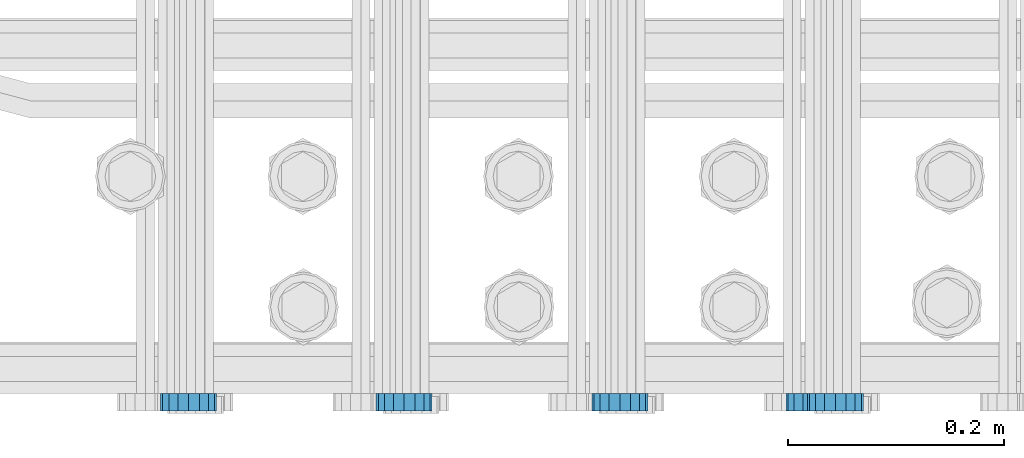
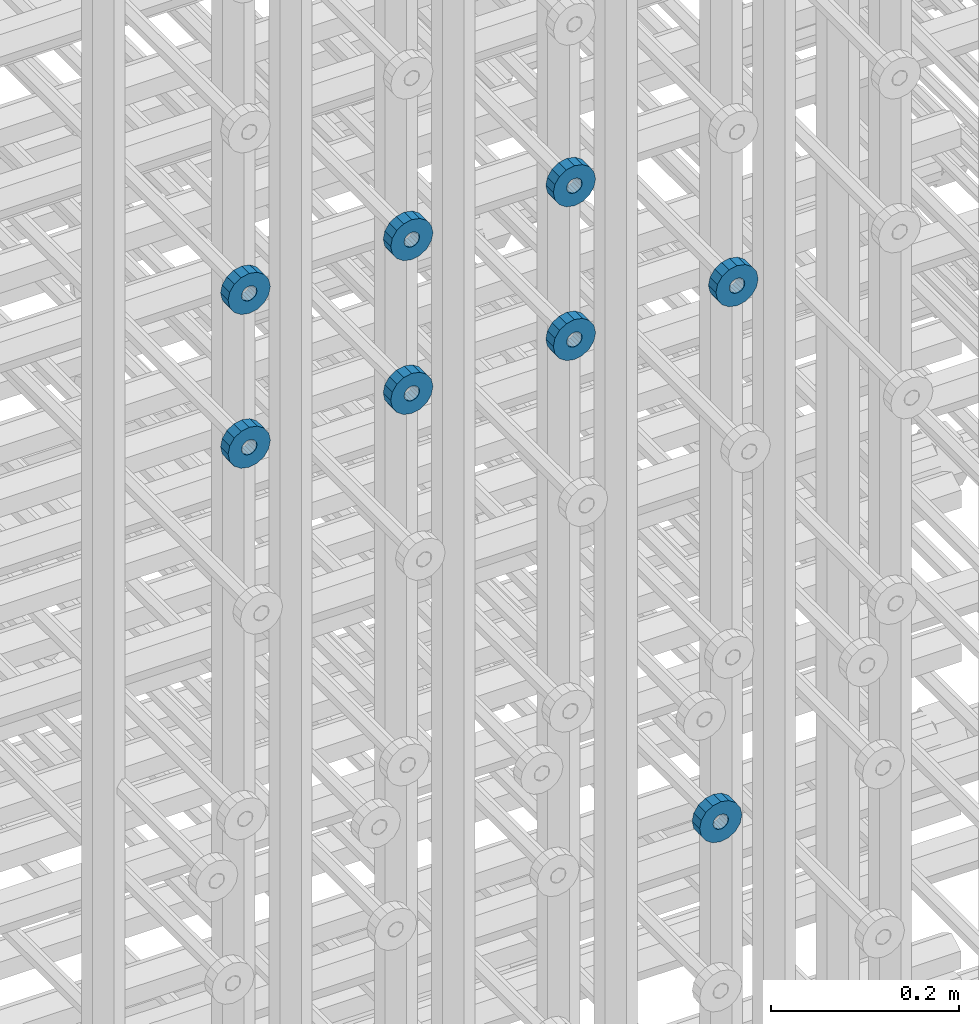
# One storey, part 118 of 177: 8 beams.
"""IFC2X3 building model written with IfcOpenShell, lengths in millimetres."""

from ifc_helpers import new_model, si_unit, frame, origin_with_axes, place, context, subcontext, project, spatial, faceted_brep, material, type_object, element, save


model = new_model("IFC2X3")

# Units and contexts
model_context_1 = context("Model", 3, precision=1e-05, world=origin_with_axes())
model_context_2 = context("Model", 3, precision=1e-05, world=origin_with_axes())
body_context = subcontext(model_context_2, "Body", "Model", "MODEL_VIEW")
ifc_project = project(units=[si_unit("LENGTHUNIT", "METRE", prefix="MILLI"), si_unit("AREAUNIT", "SQUARE_METRE"), si_unit("VOLUMEUNIT", "CUBIC_METRE"), si_unit("MASSUNIT", "GRAM", prefix="KILO"), si_unit("TIMEUNIT", "SECOND"), si_unit("PLANEANGLEUNIT", "RADIAN"), si_unit("SOLIDANGLEUNIT", "STERADIAN"), si_unit("THERMODYNAMICTEMPERATUREUNIT", "DEGREE_CELSIUS"), si_unit("LUMINOUSINTENSITYUNIT", "LUMEN")], contexts=[model_context_1])

# Site, building, storey
site_placement = place(None, origin_with_axes())
site = spatial("IfcSite", under=ifc_project, at=site_placement, CompositionType="ELEMENT")
building_placement = place(site_placement, origin_with_axes())
building = spatial("IfcBuilding", under=site, at=building_placement, Name="Undefined", CompositionType="ELEMENT")
storey_placement = place(building_placement, origin_with_axes())
storey = spatial("IfcBuildingStorey", under=building, at=storey_placement, Name="Undefined", CompositionType="ELEMENT", Elevation=0.0)

# Beams
ifc_material = material(Name="STEEL/Steel_Undefined")
beam_type = type_object("IfcBeamType", PredefinedType="NOTDEFINED")
beam_1_placement = place(storey_placement, frame((2030529.49847313, 6205075.98588592, 21549.9868126721), z_axis=(0.0, 0.0, -1.0), x_axis=(0.0, -1.0, 0.0)))
element("IfcBeam", 1, at=beam_1_placement, inside=storey, type_object=beam_type, material=ifc_material, context=body_context, shape_type="Brep", body=[
    faceted_brep([(0.0, -9.5, 0.0), (0.0, -8.77685555908829, 3.63549260746731), (16.0, -8.77685555908829, 3.63549260746731), (16.0, -9.5, 0.0), (0.0, -6.71751442085952, 6.71751442127061), (16.0, -6.71751442085952, 6.71751442127061), (0.0, -3.63549260701984, 8.77685555885546), (16.0, -3.63549260701984, 8.77685555885546), (-2.02452244836415e-12, 0.0, 9.5), (16.0, 0.0, 9.5), (0.0, 3.63549260701984, 8.77685555885546), (16.0, 3.63549260701984, 8.77685555885546), (0.0, 6.71751442085952, 6.71751442127061), (16.0, 6.71751442085952, 6.71751442127061), (0.0, 8.77685555908829, 3.63549260746731), (16.0, 8.77685555908829, 3.63549260746731), (0.0, 9.5, 0.0), (16.0, 9.5, 0.0), (0.0, 8.77685555908829, -3.63549260746731), (16.0, 8.77685555908829, -3.63549260746731), (0.0, 6.71751442085952, -6.71751442127061), (16.0, 6.71751442085952, -6.71751442127061), (0.0, 3.63549260701984, -8.77685555885546), (16.0, 3.63549260701984, -8.77685555885546), (2.02452244836415e-12, -3.69149155687865e-15, -9.5), (16.0, 0.0, -9.5), (0.0, -3.63549260701984, -8.77685555885546), (16.0, -3.63549260701984, -8.77685555885546), (0.0, -6.71751442085952, -6.71751442127061), (16.0, -6.71751442085952, -6.71751442127061), (0.0, -8.77685555908829, -3.63549260746731), (16.0, -8.77685555908829, -3.63549260746731), (0.0, -26.0, 0.0), (0.0, -24.0208678450435, -9.94976924149159), (16.0, -24.0208678450435, -9.94976924149159), (16.0, -26.0, 0.0), (0.0, -18.3847763109952, -18.3847763108497), (16.0, -18.3847763109952, -18.3847763108497), (0.0, -9.94976924173534, -24.0208678452946), (16.0, -9.94976924173534, -24.0208678452946), (0.0, 0.0, -26.0), (16.0, 0.0, -26.0), (0.0, 9.94976924173534, -24.0208678452946), (16.0, 9.94976924173534, -24.0208678452946), (0.0, 18.3847763109952, -18.3847763108497), (16.0, 18.3847763109952, -18.3847763108497), (0.0, 24.0208678450435, -9.94976924149159), (16.0, 24.0208678450435, -9.94976924149159), (0.0, 26.0, 0.0), (16.0, 26.0, 0.0), (0.0, 24.0208678450435, 9.94976924149159), (16.0, 24.0208678450435, 9.94976924149159), (0.0, 18.3847763109952, 18.3847763108497), (16.0, 18.3847763109952, 18.3847763108497), (0.0, 9.94976924173534, 24.0208678452946), (16.0, 9.94976924173534, 24.0208678452946), (0.0, 0.0, 26.0), (16.0, 0.0, 26.0), (0.0, -9.94976924173534, 24.0208678452946), (16.0, -9.94976924173534, 24.0208678452946), (0.0, -18.3847763109952, 18.3847763108497), (16.0, -18.3847763109952, 18.3847763108497), (0.0, -24.0208678450435, 9.94976924149159), (16.0, -24.0208678450435, 9.94976924149159)], [[[0, 1, 2, 3]], [[1, 4, 5, 2]], [[4, 6, 7, 5]], [[6, 8, 9, 7]], [[8, 10, 11, 9]], [[10, 12, 13, 11]], [[12, 14, 15, 13]], [[14, 16, 17, 15]], [[16, 18, 19, 17]], [[18, 20, 21, 19]], [[20, 22, 23, 21]], [[22, 24, 25, 23]], [[24, 26, 27, 25]], [[26, 28, 29, 27]], [[28, 30, 31, 29]], [[30, 0, 3, 31]], [[32, 33, 34, 35]], [[33, 36, 37, 34]], [[36, 38, 39, 37]], [[38, 40, 41, 39]], [[40, 42, 43, 41]], [[42, 44, 45, 43]], [[44, 46, 47, 45]], [[46, 48, 49, 47]], [[48, 50, 51, 49]], [[50, 52, 53, 51]], [[52, 54, 55, 53]], [[54, 56, 57, 55]], [[56, 58, 59, 57]], [[58, 60, 61, 59]], [[60, 62, 63, 61]], [[62, 32, 35, 63]], [[37, 39, 41, 43, 45, 47, 49, 51, 53, 55, 57, 59, 61, 63, 35, 34], [5, 7, 9, 11, 13, 15, 17, 19, 21, 23, 25, 27, 29, 31, 3, 2]], [[62, 60, 58, 56, 54, 52, 50, 48, 46, 44, 42, 40, 38, 36, 33, 32], [30, 28, 26, 24, 22, 20, 18, 16, 14, 12, 10, 8, 6, 4, 1, 0]]]),
])
beam_2_placement = place(storey_placement, frame((2030329.49847313, 6205075.98588592, 21549.9868126721), z_axis=(0.0, 0.0, -1.0), x_axis=(0.0, -1.0, 0.0)))
element("IfcBeam", 2, at=beam_2_placement, inside=storey, type_object=beam_type, material=ifc_material, context=body_context, shape_type="Brep", body=[
    faceted_brep([(0.0, -9.5, 0.0), (0.0, -8.77685555908829, 3.63549260746731), (16.0, -8.77685555908829, 3.63549260746731), (16.0, -9.5, 0.0), (0.0, -6.71751442085952, 6.71751442127061), (16.0, -6.71751442085952, 6.71751442127061), (0.0, -3.63549260701984, 8.77685555885546), (16.0, -3.63549260701984, 8.77685555885546), (-2.02452244836415e-12, 0.0, 9.5), (16.0, 0.0, 9.5), (0.0, 3.63549260701984, 8.77685555885546), (16.0, 3.63549260701984, 8.77685555885546), (0.0, 6.71751442085952, 6.71751442127061), (16.0, 6.71751442085952, 6.71751442127061), (0.0, 8.77685555908829, 3.63549260746731), (16.0, 8.77685555908829, 3.63549260746731), (0.0, 9.5, 0.0), (16.0, 9.5, 0.0), (0.0, 8.77685555908829, -3.63549260746731), (16.0, 8.77685555908829, -3.63549260746731), (0.0, 6.71751442085952, -6.71751442127061), (16.0, 6.71751442085952, -6.71751442127061), (0.0, 3.63549260701984, -8.77685555885546), (16.0, 3.63549260701984, -8.77685555885546), (2.02452244836415e-12, -3.69149155687865e-15, -9.5), (16.0, 0.0, -9.5), (0.0, -3.63549260701984, -8.77685555885546), (16.0, -3.63549260701984, -8.77685555885546), (0.0, -6.71751442085952, -6.71751442127061), (16.0, -6.71751442085952, -6.71751442127061), (0.0, -8.77685555908829, -3.63549260746731), (16.0, -8.77685555908829, -3.63549260746731), (0.0, -26.0, 0.0), (0.0, -24.0208678450435, -9.94976924149159), (16.0, -24.0208678450435, -9.94976924149159), (16.0, -26.0, 0.0), (0.0, -18.3847763109952, -18.3847763108497), (16.0, -18.3847763109952, -18.3847763108497), (0.0, -9.94976924173534, -24.0208678452946), (16.0, -9.94976924173534, -24.0208678452946), (0.0, 0.0, -26.0), (16.0, 0.0, -26.0), (0.0, 9.94976924173534, -24.0208678452946), (16.0, 9.94976924173534, -24.0208678452946), (0.0, 18.3847763109952, -18.3847763108497), (16.0, 18.3847763109952, -18.3847763108497), (0.0, 24.0208678450435, -9.94976924149159), (16.0, 24.0208678450435, -9.94976924149159), (0.0, 26.0, 0.0), (16.0, 26.0, 0.0), (0.0, 24.0208678450435, 9.94976924149159), (16.0, 24.0208678450435, 9.94976924149159), (0.0, 18.3847763109952, 18.3847763108497), (16.0, 18.3847763109952, 18.3847763108497), (0.0, 9.94976924173534, 24.0208678452946), (16.0, 9.94976924173534, 24.0208678452946), (0.0, 0.0, 26.0), (16.0, 0.0, 26.0), (0.0, -9.94976924173534, 24.0208678452946), (16.0, -9.94976924173534, 24.0208678452946), (0.0, -18.3847763109952, 18.3847763108497), (16.0, -18.3847763109952, 18.3847763108497), (0.0, -24.0208678450435, 9.94976924149159), (16.0, -24.0208678450435, 9.94976924149159)], [[[0, 1, 2, 3]], [[1, 4, 5, 2]], [[4, 6, 7, 5]], [[6, 8, 9, 7]], [[8, 10, 11, 9]], [[10, 12, 13, 11]], [[12, 14, 15, 13]], [[14, 16, 17, 15]], [[16, 18, 19, 17]], [[18, 20, 21, 19]], [[20, 22, 23, 21]], [[22, 24, 25, 23]], [[24, 26, 27, 25]], [[26, 28, 29, 27]], [[28, 30, 31, 29]], [[30, 0, 3, 31]], [[32, 33, 34, 35]], [[33, 36, 37, 34]], [[36, 38, 39, 37]], [[38, 40, 41, 39]], [[40, 42, 43, 41]], [[42, 44, 45, 43]], [[44, 46, 47, 45]], [[46, 48, 49, 47]], [[48, 50, 51, 49]], [[50, 52, 53, 51]], [[52, 54, 55, 53]], [[54, 56, 57, 55]], [[56, 58, 59, 57]], [[58, 60, 61, 59]], [[60, 62, 63, 61]], [[62, 32, 35, 63]], [[37, 39, 41, 43, 45, 47, 49, 51, 53, 55, 57, 59, 61, 63, 35, 34], [5, 7, 9, 11, 13, 15, 17, 19, 21, 23, 25, 27, 29, 31, 3, 2]], [[62, 60, 58, 56, 54, 52, 50, 48, 46, 44, 42, 40, 38, 36, 33, 32], [30, 28, 26, 24, 22, 20, 18, 16, 14, 12, 10, 8, 6, 4, 1, 0]]]),
])
beam_3_placement = place(storey_placement, frame((2030129.49847313, 6205075.98588592, 21549.9868126721), z_axis=(0.0, 0.0, -1.0), x_axis=(0.0, -1.0, 0.0)))
element("IfcBeam", 3, at=beam_3_placement, inside=storey, type_object=beam_type, material=ifc_material, context=body_context, shape_type="Brep", body=[
    faceted_brep([(0.0, -9.5, 0.0), (0.0, -8.77685555908829, 3.63549260746731), (16.0, -8.77685555908829, 3.63549260746731), (16.0, -9.5, 0.0), (0.0, -6.71751442085952, 6.71751442127061), (16.0, -6.71751442085952, 6.71751442127061), (0.0, -3.63549260701984, 8.77685555885546), (16.0, -3.63549260701984, 8.77685555885546), (-2.02452244836415e-12, 0.0, 9.5), (16.0, 0.0, 9.5), (0.0, 3.63549260701984, 8.77685555885546), (16.0, 3.63549260701984, 8.77685555885546), (0.0, 6.71751442085952, 6.71751442127061), (16.0, 6.71751442085952, 6.71751442127061), (0.0, 8.77685555908829, 3.63549260746731), (16.0, 8.77685555908829, 3.63549260746731), (0.0, 9.5, 0.0), (16.0, 9.5, 0.0), (0.0, 8.77685555908829, -3.63549260746731), (16.0, 8.77685555908829, -3.63549260746731), (0.0, 6.71751442085952, -6.71751442127061), (16.0, 6.71751442085952, -6.71751442127061), (0.0, 3.63549260701984, -8.77685555885546), (16.0, 3.63549260701984, -8.77685555885546), (2.02452244836415e-12, -3.69149155687865e-15, -9.5), (16.0, 0.0, -9.5), (0.0, -3.63549260701984, -8.77685555885546), (16.0, -3.63549260701984, -8.77685555885546), (0.0, -6.71751442085952, -6.71751442127061), (16.0, -6.71751442085952, -6.71751442127061), (0.0, -8.77685555908829, -3.63549260746731), (16.0, -8.77685555908829, -3.63549260746731), (0.0, -26.0, 0.0), (0.0, -24.0208678450435, -9.94976924149159), (16.0, -24.0208678450435, -9.94976924149159), (16.0, -26.0, 0.0), (0.0, -18.3847763109952, -18.3847763108497), (16.0, -18.3847763109952, -18.3847763108497), (0.0, -9.94976924173534, -24.0208678452946), (16.0, -9.94976924173534, -24.0208678452946), (0.0, 0.0, -26.0), (16.0, 0.0, -26.0), (0.0, 9.94976924173534, -24.0208678452946), (16.0, 9.94976924173534, -24.0208678452946), (0.0, 18.3847763109952, -18.3847763108497), (16.0, 18.3847763109952, -18.3847763108497), (0.0, 24.0208678450435, -9.94976924149159), (16.0, 24.0208678450435, -9.94976924149159), (0.0, 26.0, 0.0), (16.0, 26.0, 0.0), (0.0, 24.0208678450435, 9.94976924149159), (16.0, 24.0208678450435, 9.94976924149159), (0.0, 18.3847763109952, 18.3847763108497), (16.0, 18.3847763109952, 18.3847763108497), (0.0, 9.94976924173534, 24.0208678452946), (16.0, 9.94976924173534, 24.0208678452946), (0.0, 0.0, 26.0), (16.0, 0.0, 26.0), (0.0, -9.94976924173534, 24.0208678452946), (16.0, -9.94976924173534, 24.0208678452946), (0.0, -18.3847763109952, 18.3847763108497), (16.0, -18.3847763109952, 18.3847763108497), (0.0, -24.0208678450435, 9.94976924149159), (16.0, -24.0208678450435, 9.94976924149159)], [[[0, 1, 2, 3]], [[1, 4, 5, 2]], [[4, 6, 7, 5]], [[6, 8, 9, 7]], [[8, 10, 11, 9]], [[10, 12, 13, 11]], [[12, 14, 15, 13]], [[14, 16, 17, 15]], [[16, 18, 19, 17]], [[18, 20, 21, 19]], [[20, 22, 23, 21]], [[22, 24, 25, 23]], [[24, 26, 27, 25]], [[26, 28, 29, 27]], [[28, 30, 31, 29]], [[30, 0, 3, 31]], [[32, 33, 34, 35]], [[33, 36, 37, 34]], [[36, 38, 39, 37]], [[38, 40, 41, 39]], [[40, 42, 43, 41]], [[42, 44, 45, 43]], [[44, 46, 47, 45]], [[46, 48, 49, 47]], [[48, 50, 51, 49]], [[50, 52, 53, 51]], [[52, 54, 55, 53]], [[54, 56, 57, 55]], [[56, 58, 59, 57]], [[58, 60, 61, 59]], [[60, 62, 63, 61]], [[62, 32, 35, 63]], [[37, 39, 41, 43, 45, 47, 49, 51, 53, 55, 57, 59, 61, 63, 35, 34], [5, 7, 9, 11, 13, 15, 17, 19, 21, 23, 25, 27, 29, 31, 3, 2]], [[62, 60, 58, 56, 54, 52, 50, 48, 46, 44, 42, 40, 38, 36, 33, 32], [30, 28, 26, 24, 22, 20, 18, 16, 14, 12, 10, 8, 6, 4, 1, 0]]]),
])
beam_4_placement = place(storey_placement, frame((2030729.49847313, 6205075.98588576, 21349.9868126721), z_axis=(0.0, 0.0, -1.0), x_axis=(0.0, -1.0, 0.0)))
element("IfcBeam", 4, at=beam_4_placement, inside=storey, type_object=beam_type, material=ifc_material, context=body_context, shape_type="Brep", body=[
    faceted_brep([(0.0, -9.5, 0.0), (0.0, -8.77685555908829, 3.63549260746731), (16.0, -8.77685555908829, 3.63549260746731), (16.0, -9.5, 0.0), (0.0, -6.71751442085952, 6.71751442127061), (16.0, -6.71751442085952, 6.71751442127061), (0.0, -3.63549260701984, 8.77685555885546), (16.0, -3.63549260701984, 8.77685555885546), (-2.02452244836415e-12, 0.0, 9.5), (16.0, 0.0, 9.5), (0.0, 3.63549260701984, 8.77685555885546), (16.0, 3.63549260701984, 8.77685555885546), (0.0, 6.71751442085952, 6.71751442127061), (16.0, 6.71751442085952, 6.71751442127061), (0.0, 8.77685555908829, 3.63549260746731), (16.0, 8.77685555908829, 3.63549260746731), (0.0, 9.5, 0.0), (16.0, 9.5, 0.0), (0.0, 8.77685555908829, -3.63549260746731), (16.0, 8.77685555908829, -3.63549260746731), (0.0, 6.71751442085952, -6.71751442127061), (16.0, 6.71751442085952, -6.71751442127061), (0.0, 3.63549260701984, -8.77685555885546), (16.0, 3.63549260701984, -8.77685555885546), (2.02452244836415e-12, -3.69149155687865e-15, -9.5), (16.0, 0.0, -9.5), (0.0, -3.63549260701984, -8.77685555885546), (16.0, -3.63549260701984, -8.77685555885546), (0.0, -6.71751442085952, -6.71751442127061), (16.0, -6.71751442085952, -6.71751442127061), (0.0, -8.77685555908829, -3.63549260746731), (16.0, -8.77685555908829, -3.63549260746731), (0.0, -26.0, 0.0), (0.0, -24.0208678450435, -9.94976924149159), (16.0, -24.0208678450435, -9.94976924149159), (16.0, -26.0, 0.0), (0.0, -18.3847763109952, -18.3847763108497), (16.0, -18.3847763109952, -18.3847763108497), (0.0, -9.94976924173534, -24.0208678452946), (16.0, -9.94976924173534, -24.0208678452946), (0.0, 0.0, -26.0), (16.0, 0.0, -26.0), (0.0, 9.94976924173534, -24.0208678452946), (16.0, 9.94976924173534, -24.0208678452946), (0.0, 18.3847763109952, -18.3847763108497), (16.0, 18.3847763109952, -18.3847763108497), (0.0, 24.0208678450435, -9.94976924149159), (16.0, 24.0208678450435, -9.94976924149159), (0.0, 26.0, 0.0), (16.0, 26.0, 0.0), (0.0, 24.0208678450435, 9.94976924149159), (16.0, 24.0208678450435, 9.94976924149159), (0.0, 18.3847763109952, 18.3847763108497), (16.0, 18.3847763109952, 18.3847763108497), (0.0, 9.94976924173534, 24.0208678452946), (16.0, 9.94976924173534, 24.0208678452946), (0.0, 0.0, 26.0), (16.0, 0.0, 26.0), (0.0, -9.94976924173534, 24.0208678452946), (16.0, -9.94976924173534, 24.0208678452946), (0.0, -18.3847763109952, 18.3847763108497), (16.0, -18.3847763109952, 18.3847763108497), (0.0, -24.0208678450435, 9.94976924149159), (16.0, -24.0208678450435, 9.94976924149159)], [[[0, 1, 2, 3]], [[1, 4, 5, 2]], [[4, 6, 7, 5]], [[6, 8, 9, 7]], [[8, 10, 11, 9]], [[10, 12, 13, 11]], [[12, 14, 15, 13]], [[14, 16, 17, 15]], [[16, 18, 19, 17]], [[18, 20, 21, 19]], [[20, 22, 23, 21]], [[22, 24, 25, 23]], [[24, 26, 27, 25]], [[26, 28, 29, 27]], [[28, 30, 31, 29]], [[30, 0, 3, 31]], [[32, 33, 34, 35]], [[33, 36, 37, 34]], [[36, 38, 39, 37]], [[38, 40, 41, 39]], [[40, 42, 43, 41]], [[42, 44, 45, 43]], [[44, 46, 47, 45]], [[46, 48, 49, 47]], [[48, 50, 51, 49]], [[50, 52, 53, 51]], [[52, 54, 55, 53]], [[54, 56, 57, 55]], [[56, 58, 59, 57]], [[58, 60, 61, 59]], [[60, 62, 63, 61]], [[62, 32, 35, 63]], [[37, 39, 41, 43, 45, 47, 49, 51, 53, 55, 57, 59, 61, 63, 35, 34], [5, 7, 9, 11, 13, 15, 17, 19, 21, 23, 25, 27, 29, 31, 3, 2]], [[62, 60, 58, 56, 54, 52, 50, 48, 46, 44, 42, 40, 38, 36, 33, 32], [30, 28, 26, 24, 22, 20, 18, 16, 14, 12, 10, 8, 6, 4, 1, 0]]]),
])
beam_5_placement = place(storey_placement, frame((2030529.49847313, 6205075.98588576, 21349.9868126721), z_axis=(0.0, 0.0, -1.0), x_axis=(0.0, -1.0, 0.0)))
element("IfcBeam", 5, at=beam_5_placement, inside=storey, type_object=beam_type, material=ifc_material, context=body_context, shape_type="Brep", body=[
    faceted_brep([(0.0, -9.5, 0.0), (0.0, -8.77685555908829, 3.63549260746731), (16.0, -8.77685555908829, 3.63549260746731), (16.0, -9.5, 0.0), (0.0, -6.71751442085952, 6.71751442127061), (16.0, -6.71751442085952, 6.71751442127061), (0.0, -3.63549260701984, 8.77685555885546), (16.0, -3.63549260701984, 8.77685555885546), (-2.02452244836415e-12, 0.0, 9.5), (16.0, 0.0, 9.5), (0.0, 3.63549260701984, 8.77685555885546), (16.0, 3.63549260701984, 8.77685555885546), (0.0, 6.71751442085952, 6.71751442127061), (16.0, 6.71751442085952, 6.71751442127061), (0.0, 8.77685555908829, 3.63549260746731), (16.0, 8.77685555908829, 3.63549260746731), (0.0, 9.5, 0.0), (16.0, 9.5, 0.0), (0.0, 8.77685555908829, -3.63549260746731), (16.0, 8.77685555908829, -3.63549260746731), (0.0, 6.71751442085952, -6.71751442127061), (16.0, 6.71751442085952, -6.71751442127061), (0.0, 3.63549260701984, -8.77685555885546), (16.0, 3.63549260701984, -8.77685555885546), (2.02452244836415e-12, -3.69149155687865e-15, -9.5), (16.0, 0.0, -9.5), (0.0, -3.63549260701984, -8.77685555885546), (16.0, -3.63549260701984, -8.77685555885546), (0.0, -6.71751442085952, -6.71751442127061), (16.0, -6.71751442085952, -6.71751442127061), (0.0, -8.77685555908829, -3.63549260746731), (16.0, -8.77685555908829, -3.63549260746731), (0.0, -26.0, 0.0), (0.0, -24.0208678450435, -9.94976924149159), (16.0, -24.0208678450435, -9.94976924149159), (16.0, -26.0, 0.0), (0.0, -18.3847763109952, -18.3847763108497), (16.0, -18.3847763109952, -18.3847763108497), (0.0, -9.94976924173534, -24.0208678452946), (16.0, -9.94976924173534, -24.0208678452946), (0.0, 0.0, -26.0), (16.0, 0.0, -26.0), (0.0, 9.94976924173534, -24.0208678452946), (16.0, 9.94976924173534, -24.0208678452946), (0.0, 18.3847763109952, -18.3847763108497), (16.0, 18.3847763109952, -18.3847763108497), (0.0, 24.0208678450435, -9.94976924149159), (16.0, 24.0208678450435, -9.94976924149159), (0.0, 26.0, 0.0), (16.0, 26.0, 0.0), (0.0, 24.0208678450435, 9.94976924149159), (16.0, 24.0208678450435, 9.94976924149159), (0.0, 18.3847763109952, 18.3847763108497), (16.0, 18.3847763109952, 18.3847763108497), (0.0, 9.94976924173534, 24.0208678452946), (16.0, 9.94976924173534, 24.0208678452946), (0.0, 0.0, 26.0), (16.0, 0.0, 26.0), (0.0, -9.94976924173534, 24.0208678452946), (16.0, -9.94976924173534, 24.0208678452946), (0.0, -18.3847763109952, 18.3847763108497), (16.0, -18.3847763109952, 18.3847763108497), (0.0, -24.0208678450435, 9.94976924149159), (16.0, -24.0208678450435, 9.94976924149159)], [[[0, 1, 2, 3]], [[1, 4, 5, 2]], [[4, 6, 7, 5]], [[6, 8, 9, 7]], [[8, 10, 11, 9]], [[10, 12, 13, 11]], [[12, 14, 15, 13]], [[14, 16, 17, 15]], [[16, 18, 19, 17]], [[18, 20, 21, 19]], [[20, 22, 23, 21]], [[22, 24, 25, 23]], [[24, 26, 27, 25]], [[26, 28, 29, 27]], [[28, 30, 31, 29]], [[30, 0, 3, 31]], [[32, 33, 34, 35]], [[33, 36, 37, 34]], [[36, 38, 39, 37]], [[38, 40, 41, 39]], [[40, 42, 43, 41]], [[42, 44, 45, 43]], [[44, 46, 47, 45]], [[46, 48, 49, 47]], [[48, 50, 51, 49]], [[50, 52, 53, 51]], [[52, 54, 55, 53]], [[54, 56, 57, 55]], [[56, 58, 59, 57]], [[58, 60, 61, 59]], [[60, 62, 63, 61]], [[62, 32, 35, 63]], [[37, 39, 41, 43, 45, 47, 49, 51, 53, 55, 57, 59, 61, 63, 35, 34], [5, 7, 9, 11, 13, 15, 17, 19, 21, 23, 25, 27, 29, 31, 3, 2]], [[62, 60, 58, 56, 54, 52, 50, 48, 46, 44, 42, 40, 38, 36, 33, 32], [30, 28, 26, 24, 22, 20, 18, 16, 14, 12, 10, 8, 6, 4, 1, 0]]]),
])
beam_6_placement = place(storey_placement, frame((2030329.49847313, 6205075.98588576, 21349.9868126721), z_axis=(0.0, 0.0, -1.0), x_axis=(0.0, -1.0, 0.0)))
element("IfcBeam", 6, at=beam_6_placement, inside=storey, type_object=beam_type, material=ifc_material, context=body_context, shape_type="Brep", body=[
    faceted_brep([(0.0, -9.5, 0.0), (0.0, -8.77685555908829, 3.63549260746731), (16.0, -8.77685555908829, 3.63549260746731), (16.0, -9.5, 0.0), (0.0, -6.71751442085952, 6.71751442127061), (16.0, -6.71751442085952, 6.71751442127061), (0.0, -3.63549260701984, 8.77685555885546), (16.0, -3.63549260701984, 8.77685555885546), (-2.02452244836415e-12, 0.0, 9.5), (16.0, 0.0, 9.5), (0.0, 3.63549260701984, 8.77685555885546), (16.0, 3.63549260701984, 8.77685555885546), (0.0, 6.71751442085952, 6.71751442127061), (16.0, 6.71751442085952, 6.71751442127061), (0.0, 8.77685555908829, 3.63549260746731), (16.0, 8.77685555908829, 3.63549260746731), (0.0, 9.5, 0.0), (16.0, 9.5, 0.0), (0.0, 8.77685555908829, -3.63549260746731), (16.0, 8.77685555908829, -3.63549260746731), (0.0, 6.71751442085952, -6.71751442127061), (16.0, 6.71751442085952, -6.71751442127061), (0.0, 3.63549260701984, -8.77685555885546), (16.0, 3.63549260701984, -8.77685555885546), (2.02452244836415e-12, -3.69149155687865e-15, -9.5), (16.0, 0.0, -9.5), (0.0, -3.63549260701984, -8.77685555885546), (16.0, -3.63549260701984, -8.77685555885546), (0.0, -6.71751442085952, -6.71751442127061), (16.0, -6.71751442085952, -6.71751442127061), (0.0, -8.77685555908829, -3.63549260746731), (16.0, -8.77685555908829, -3.63549260746731), (0.0, -26.0, 0.0), (0.0, -24.0208678450435, -9.94976924149159), (16.0, -24.0208678450435, -9.94976924149159), (16.0, -26.0, 0.0), (0.0, -18.3847763109952, -18.3847763108497), (16.0, -18.3847763109952, -18.3847763108497), (0.0, -9.94976924173534, -24.0208678452946), (16.0, -9.94976924173534, -24.0208678452946), (0.0, 0.0, -26.0), (16.0, 0.0, -26.0), (0.0, 9.94976924173534, -24.0208678452946), (16.0, 9.94976924173534, -24.0208678452946), (0.0, 18.3847763109952, -18.3847763108497), (16.0, 18.3847763109952, -18.3847763108497), (0.0, 24.0208678450435, -9.94976924149159), (16.0, 24.0208678450435, -9.94976924149159), (0.0, 26.0, 0.0), (16.0, 26.0, 0.0), (0.0, 24.0208678450435, 9.94976924149159), (16.0, 24.0208678450435, 9.94976924149159), (0.0, 18.3847763109952, 18.3847763108497), (16.0, 18.3847763109952, 18.3847763108497), (0.0, 9.94976924173534, 24.0208678452946), (16.0, 9.94976924173534, 24.0208678452946), (0.0, 0.0, 26.0), (16.0, 0.0, 26.0), (0.0, -9.94976924173534, 24.0208678452946), (16.0, -9.94976924173534, 24.0208678452946), (0.0, -18.3847763109952, 18.3847763108497), (16.0, -18.3847763109952, 18.3847763108497), (0.0, -24.0208678450435, 9.94976924149159), (16.0, -24.0208678450435, 9.94976924149159)], [[[0, 1, 2, 3]], [[1, 4, 5, 2]], [[4, 6, 7, 5]], [[6, 8, 9, 7]], [[8, 10, 11, 9]], [[10, 12, 13, 11]], [[12, 14, 15, 13]], [[14, 16, 17, 15]], [[16, 18, 19, 17]], [[18, 20, 21, 19]], [[20, 22, 23, 21]], [[22, 24, 25, 23]], [[24, 26, 27, 25]], [[26, 28, 29, 27]], [[28, 30, 31, 29]], [[30, 0, 3, 31]], [[32, 33, 34, 35]], [[33, 36, 37, 34]], [[36, 38, 39, 37]], [[38, 40, 41, 39]], [[40, 42, 43, 41]], [[42, 44, 45, 43]], [[44, 46, 47, 45]], [[46, 48, 49, 47]], [[48, 50, 51, 49]], [[50, 52, 53, 51]], [[52, 54, 55, 53]], [[54, 56, 57, 55]], [[56, 58, 59, 57]], [[58, 60, 61, 59]], [[60, 62, 63, 61]], [[62, 32, 35, 63]], [[37, 39, 41, 43, 45, 47, 49, 51, 53, 55, 57, 59, 61, 63, 35, 34], [5, 7, 9, 11, 13, 15, 17, 19, 21, 23, 25, 27, 29, 31, 3, 2]], [[62, 60, 58, 56, 54, 52, 50, 48, 46, 44, 42, 40, 38, 36, 33, 32], [30, 28, 26, 24, 22, 20, 18, 16, 14, 12, 10, 8, 6, 4, 1, 0]]]),
])
beam_7_placement = place(storey_placement, frame((2030129.49847313, 6205075.98588576, 21349.9868126721), z_axis=(0.0, 0.0, -1.0), x_axis=(0.0, -1.0, 0.0)))
element("IfcBeam", 7, at=beam_7_placement, inside=storey, type_object=beam_type, material=ifc_material, context=body_context, shape_type="Brep", body=[
    faceted_brep([(0.0, -9.5, 0.0), (0.0, -8.77685555908829, 3.63549260746731), (16.0, -8.77685555908829, 3.63549260746731), (16.0, -9.5, 0.0), (0.0, -6.71751442085952, 6.71751442127061), (16.0, -6.71751442085952, 6.71751442127061), (0.0, -3.63549260701984, 8.77685555885546), (16.0, -3.63549260701984, 8.77685555885546), (-2.02452244836415e-12, 0.0, 9.5), (16.0, 0.0, 9.5), (0.0, 3.63549260701984, 8.77685555885546), (16.0, 3.63549260701984, 8.77685555885546), (0.0, 6.71751442085952, 6.71751442127061), (16.0, 6.71751442085952, 6.71751442127061), (0.0, 8.77685555908829, 3.63549260746731), (16.0, 8.77685555908829, 3.63549260746731), (0.0, 9.5, 0.0), (16.0, 9.5, 0.0), (0.0, 8.77685555908829, -3.63549260746731), (16.0, 8.77685555908829, -3.63549260746731), (0.0, 6.71751442085952, -6.71751442127061), (16.0, 6.71751442085952, -6.71751442127061), (0.0, 3.63549260701984, -8.77685555885546), (16.0, 3.63549260701984, -8.77685555885546), (2.02452244836415e-12, -3.69149155687865e-15, -9.5), (16.0, 0.0, -9.5), (0.0, -3.63549260701984, -8.77685555885546), (16.0, -3.63549260701984, -8.77685555885546), (0.0, -6.71751442085952, -6.71751442127061), (16.0, -6.71751442085952, -6.71751442127061), (0.0, -8.77685555908829, -3.63549260746731), (16.0, -8.77685555908829, -3.63549260746731), (0.0, -26.0, 0.0), (0.0, -24.0208678450435, -9.94976924149159), (16.0, -24.0208678450435, -9.94976924149159), (16.0, -26.0, 0.0), (0.0, -18.3847763109952, -18.3847763108497), (16.0, -18.3847763109952, -18.3847763108497), (0.0, -9.94976924173534, -24.0208678452946), (16.0, -9.94976924173534, -24.0208678452946), (0.0, 0.0, -26.0), (16.0, 0.0, -26.0), (0.0, 9.94976924173534, -24.0208678452946), (16.0, 9.94976924173534, -24.0208678452946), (0.0, 18.3847763109952, -18.3847763108497), (16.0, 18.3847763109952, -18.3847763108497), (0.0, 24.0208678450435, -9.94976924149159), (16.0, 24.0208678450435, -9.94976924149159), (0.0, 26.0, 0.0), (16.0, 26.0, 0.0), (0.0, 24.0208678450435, 9.94976924149159), (16.0, 24.0208678450435, 9.94976924149159), (0.0, 18.3847763109952, 18.3847763108497), (16.0, 18.3847763109952, 18.3847763108497), (0.0, 9.94976924173534, 24.0208678452946), (16.0, 9.94976924173534, 24.0208678452946), (0.0, 0.0, 26.0), (16.0, 0.0, 26.0), (0.0, -9.94976924173534, 24.0208678452946), (16.0, -9.94976924173534, 24.0208678452946), (0.0, -18.3847763109952, 18.3847763108497), (16.0, -18.3847763109952, 18.3847763108497), (0.0, -24.0208678450435, 9.94976924149159), (16.0, -24.0208678450435, 9.94976924149159)], [[[0, 1, 2, 3]], [[1, 4, 5, 2]], [[4, 6, 7, 5]], [[6, 8, 9, 7]], [[8, 10, 11, 9]], [[10, 12, 13, 11]], [[12, 14, 15, 13]], [[14, 16, 17, 15]], [[16, 18, 19, 17]], [[18, 20, 21, 19]], [[20, 22, 23, 21]], [[22, 24, 25, 23]], [[24, 26, 27, 25]], [[26, 28, 29, 27]], [[28, 30, 31, 29]], [[30, 0, 3, 31]], [[32, 33, 34, 35]], [[33, 36, 37, 34]], [[36, 38, 39, 37]], [[38, 40, 41, 39]], [[40, 42, 43, 41]], [[42, 44, 45, 43]], [[44, 46, 47, 45]], [[46, 48, 49, 47]], [[48, 50, 51, 49]], [[50, 52, 53, 51]], [[52, 54, 55, 53]], [[54, 56, 57, 55]], [[56, 58, 59, 57]], [[58, 60, 61, 59]], [[60, 62, 63, 61]], [[62, 32, 35, 63]], [[37, 39, 41, 43, 45, 47, 49, 51, 53, 55, 57, 59, 61, 63, 35, 34], [5, 7, 9, 11, 13, 15, 17, 19, 21, 23, 25, 27, 29, 31, 3, 2]], [[62, 60, 58, 56, 54, 52, 50, 48, 46, 44, 42, 40, 38, 36, 33, 32], [30, 28, 26, 24, 22, 20, 18, 16, 14, 12, 10, 8, 6, 4, 1, 0]]]),
])
beam_8_placement = place(storey_placement, frame((2030709.49847313, 6205075.98588034, 20659.9868114202), z_axis=(0.0, 0.0, -1.0), x_axis=(0.0, -1.0, 0.0)))
element("IfcBeam", 8, at=beam_8_placement, inside=storey, type_object=beam_type, material=ifc_material, context=body_context, shape_type="Brep", body=[
    faceted_brep([(0.0, -9.5, 0.0), (0.0, -8.77685555908829, 3.63549260746731), (16.0, -8.77685555908829, 3.63549260746731), (16.0, -9.5, 0.0), (0.0, -6.71751442085952, 6.71751442127061), (16.0, -6.71751442085952, 6.71751442127061), (0.0, -3.63549260701984, 8.77685555885546), (16.0, -3.63549260701984, 8.77685555885546), (-2.02452244836415e-12, 0.0, 9.5), (16.0, 0.0, 9.5), (0.0, 3.63549260701984, 8.77685555885546), (16.0, 3.63549260701984, 8.77685555885546), (0.0, 6.71751442085952, 6.71751442127061), (16.0, 6.71751442085952, 6.71751442127061), (0.0, 8.77685555908829, 3.63549260746731), (16.0, 8.77685555908829, 3.63549260746731), (0.0, 9.5, 0.0), (16.0, 9.5, 0.0), (0.0, 8.77685555908829, -3.63549260746731), (16.0, 8.77685555908829, -3.63549260746731), (0.0, 6.71751442085952, -6.71751442127061), (16.0, 6.71751442085952, -6.71751442127061), (0.0, 3.63549260701984, -8.77685555885546), (16.0, 3.63549260701984, -8.77685555885546), (2.02452244836415e-12, -3.69149155687865e-15, -9.5), (16.0, 0.0, -9.5), (0.0, -3.63549260701984, -8.77685555885546), (16.0, -3.63549260701984, -8.77685555885546), (0.0, -6.71751442085952, -6.71751442127061), (16.0, -6.71751442085952, -6.71751442127061), (0.0, -8.77685555908829, -3.63549260746731), (16.0, -8.77685555908829, -3.63549260746731), (0.0, -26.0, 0.0), (0.0, -24.0208678450435, -9.94976924149159), (16.0, -24.0208678450435, -9.94976924149159), (16.0, -26.0, 0.0), (0.0, -18.3847763109952, -18.3847763108497), (16.0, -18.3847763109952, -18.3847763108497), (0.0, -9.94976924173534, -24.0208678452946), (16.0, -9.94976924173534, -24.0208678452946), (0.0, 0.0, -26.0), (16.0, 0.0, -26.0), (0.0, 9.94976924173534, -24.0208678452946), (16.0, 9.94976924173534, -24.0208678452946), (0.0, 18.3847763109952, -18.3847763108497), (16.0, 18.3847763109952, -18.3847763108497), (0.0, 24.0208678450435, -9.94976924149159), (16.0, 24.0208678450435, -9.94976924149159), (0.0, 26.0, 0.0), (16.0, 26.0, 0.0), (0.0, 24.0208678450435, 9.94976924149159), (16.0, 24.0208678450435, 9.94976924149159), (0.0, 18.3847763109952, 18.3847763108497), (16.0, 18.3847763109952, 18.3847763108497), (0.0, 9.94976924173534, 24.0208678452946), (16.0, 9.94976924173534, 24.0208678452946), (0.0, 0.0, 26.0), (16.0, 0.0, 26.0), (0.0, -9.94976924173534, 24.0208678452946), (16.0, -9.94976924173534, 24.0208678452946), (0.0, -18.3847763109952, 18.3847763108497), (16.0, -18.3847763109952, 18.3847763108497), (0.0, -24.0208678450435, 9.94976924149159), (16.0, -24.0208678450435, 9.94976924149159)], [[[0, 1, 2, 3]], [[1, 4, 5, 2]], [[4, 6, 7, 5]], [[6, 8, 9, 7]], [[8, 10, 11, 9]], [[10, 12, 13, 11]], [[12, 14, 15, 13]], [[14, 16, 17, 15]], [[16, 18, 19, 17]], [[18, 20, 21, 19]], [[20, 22, 23, 21]], [[22, 24, 25, 23]], [[24, 26, 27, 25]], [[26, 28, 29, 27]], [[28, 30, 31, 29]], [[30, 0, 3, 31]], [[32, 33, 34, 35]], [[33, 36, 37, 34]], [[36, 38, 39, 37]], [[38, 40, 41, 39]], [[40, 42, 43, 41]], [[42, 44, 45, 43]], [[44, 46, 47, 45]], [[46, 48, 49, 47]], [[48, 50, 51, 49]], [[50, 52, 53, 51]], [[52, 54, 55, 53]], [[54, 56, 57, 55]], [[56, 58, 59, 57]], [[58, 60, 61, 59]], [[60, 62, 63, 61]], [[62, 32, 35, 63]], [[37, 39, 41, 43, 45, 47, 49, 51, 53, 55, 57, 59, 61, 63, 35, 34], [5, 7, 9, 11, 13, 15, 17, 19, 21, 23, 25, 27, 29, 31, 3, 2]], [[62, 60, 58, 56, 54, 52, 50, 48, 46, 44, 42, 40, 38, 36, 33, 32], [30, 28, 26, 24, 22, 20, 18, 16, 14, 12, 10, 8, 6, 4, 1, 0]]]),
])

save(model, "model.ifc")
